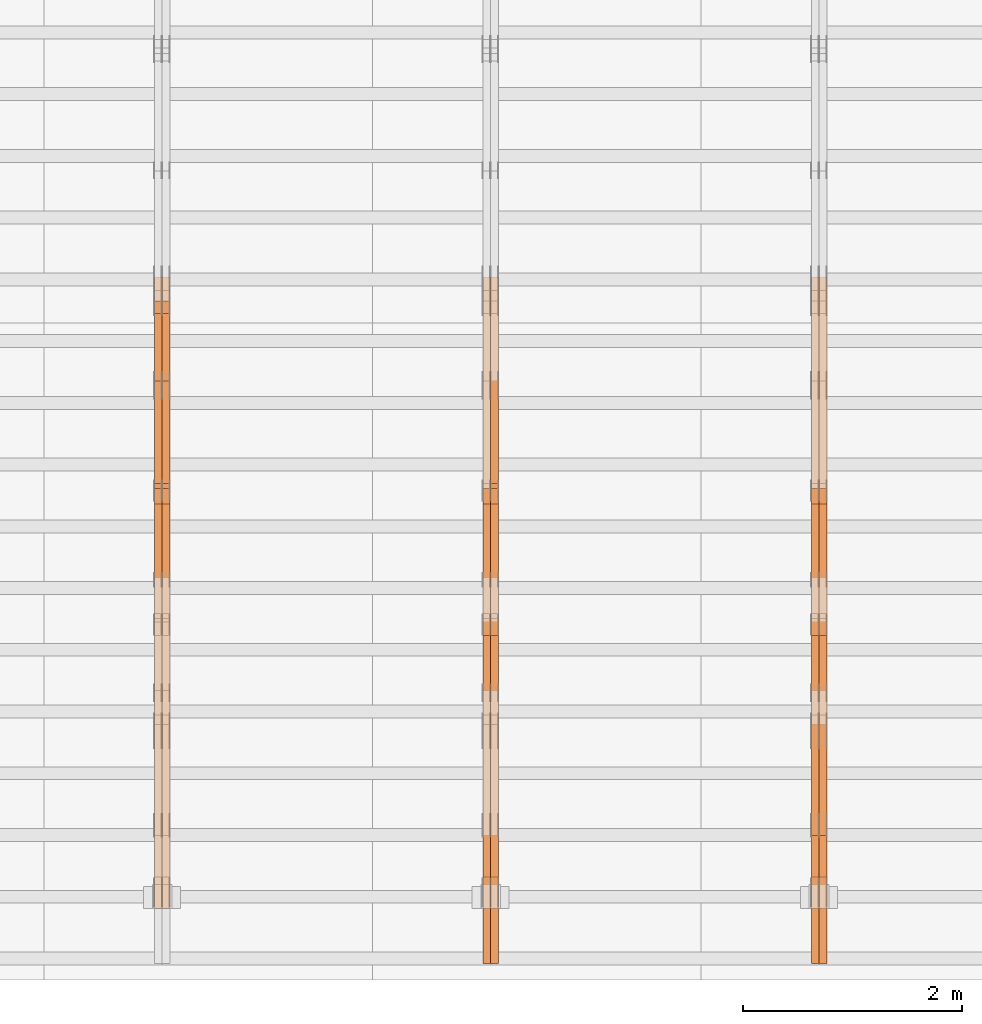
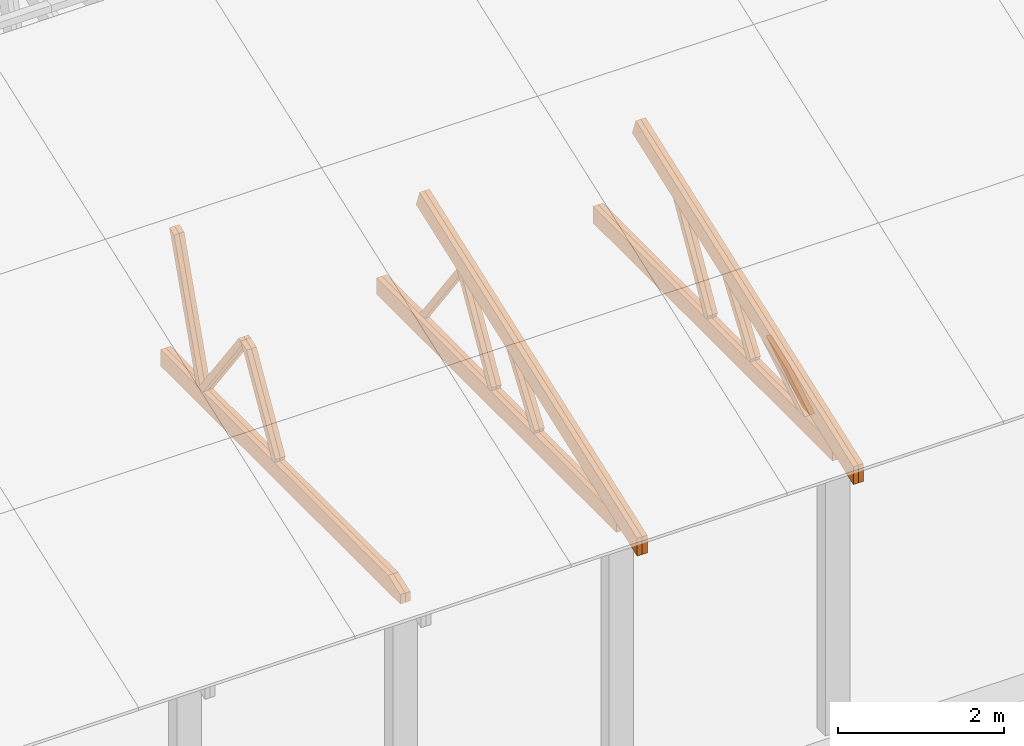
# One storey, part 21 of 189: 27 proxies.
"""IFC2X3 building model written with IfcOpenShell, lengths in millimetres."""

from ifc_helpers import new_model, entity, si_unit, converted_unit, derived_unit, direction, frame, origin, place, context, subcontext, project, spatial, polyline, outline, extrude, source, transform, mapped, material, type_object, type_shapes, element, save


model = new_model("IFC2X3")

# Units and contexts
model_context = context("Model", 3, precision=0.01, world=origin(), true_north=direction((6.12303176911189e-17, 1.0)))
body_context = subcontext(model_context, "Body", "Model", "MODEL_VIEW")
ifc_project = project(units=[si_unit("LENGTHUNIT", "METRE", prefix="MILLI"), si_unit("AREAUNIT", "SQUARE_METRE"), si_unit("VOLUMEUNIT", "CUBIC_METRE"), converted_unit("PLANEANGLEUNIT", "DEGREE", entity("IfcRatioMeasure", 0.0174532925199433), si_unit("PLANEANGLEUNIT", "RADIAN"), dimensions=[0, 0, 0, 0, 0, 0, 0]), si_unit("MASSUNIT", "GRAM", prefix="KILO"), derived_unit("MASSDENSITYUNIT", [(si_unit("MASSUNIT", "GRAM", prefix="KILO"), 1), (si_unit("LENGTHUNIT", "METRE"), -3)]), si_unit("TIMEUNIT", "SECOND"), si_unit("FREQUENCYUNIT", "HERTZ"), si_unit("THERMODYNAMICTEMPERATUREUNIT", "DEGREE_CELSIUS"), derived_unit("THERMALTRANSMITTANCEUNIT", [(si_unit("MASSUNIT", "GRAM", prefix="KILO"), 1), (si_unit("THERMODYNAMICTEMPERATUREUNIT", "KELVIN"), -1), (si_unit("TIMEUNIT", "SECOND"), -3)]), derived_unit("VOLUMETRICFLOWRATEUNIT", [(si_unit("LENGTHUNIT", "METRE"), 3), (si_unit("TIMEUNIT", "SECOND"), -1)]), si_unit("ELECTRICCURRENTUNIT", "AMPERE"), si_unit("ELECTRICVOLTAGEUNIT", "VOLT"), si_unit("POWERUNIT", "WATT"), si_unit("FORCEUNIT", "NEWTON"), si_unit("ILLUMINANCEUNIT", "LUX"), si_unit("LUMINOUSFLUXUNIT", "LUMEN"), si_unit("LUMINOUSINTENSITYUNIT", "CANDELA"), derived_unit("USERDEFINED", [(si_unit("MASSUNIT", "GRAM", prefix="KILO"), -1), (si_unit("LENGTHUNIT", "METRE"), -2), (si_unit("TIMEUNIT", "SECOND"), 3), (si_unit("LUMINOUSFLUXUNIT", "LUMEN"), 1)]), derived_unit("LINEARVELOCITYUNIT", [(si_unit("LENGTHUNIT", "METRE"), 1), (si_unit("TIMEUNIT", "SECOND"), -1)]), si_unit("PRESSUREUNIT", "PASCAL"), derived_unit("USERDEFINED", [(si_unit("LENGTHUNIT", "METRE"), -2), (si_unit("MASSUNIT", "GRAM", prefix="KILO"), 1), (si_unit("TIMEUNIT", "SECOND"), -2)])], contexts=[model_context])

# Site, building, storey
site_placement = place(None, origin())
site = spatial("IfcSite", under=ifc_project, at=site_placement, CompositionType="ELEMENT")
building_placement = place(site_placement, origin())
building = spatial("IfcBuilding", under=site, at=building_placement, CompositionType="ELEMENT")
storey_placement = place(building_placement, origin())
storey = spatial("IfcBuildingStorey", under=building, at=storey_placement, Name="Default", CompositionType="ELEMENT", Elevation=0.0)

# Proxies
ifc_material_1 = material(Name="IfcSurfaceStyle #113364")
building_element_proxy_type_1 = type_object("IfcBuildingElementProxyType", Name="T1-W11 113362", PredefinedType="NOTDEFINED", material=ifc_material_1)
shared_shape_1 = source(origin(), body_context, "Body", "SweptSolid", [
    extrude(outline(polyline([(593.358012843793, -552.565239103314), (742.388662259985, -552.565239103314), (-410.498749190676, 401.275038694583), (-462.246133468927, 382.44069706518), (-463.001792444175, 321.414742446865), (593.358012843793, -552.565239103314)])), frame((599.94412413079, 47.5003788877286, 0.0), z_axis=(0.0, 0.0, 1.0), x_axis=(0.770483455324544, 0.637459994879013, 0.0)), (0.0, 0.0, 1.0), 69.9999999999999),
])
type_shapes(building_element_proxy_type_1, [shared_shape_1])
proxy_1_placement = place(building_placement, frame((21300.0, 2983.26655629375, 269.034992751429), z_axis=(-1.0, 0.0, 0.0), x_axis=(0.0, 0.505995901100606, 0.862535882192379)))
element("IfcBuildingElementProxy", 1, at=proxy_1_placement, inside=storey, type_object=building_element_proxy_type_1, material=ifc_material_1, Name="T1-W11", context=body_context, shape_type="MappedRepresentation", body=[
    mapped(shared_shape_1, transform((0.0, 0.0, 0.0), scale=1.0)),
])
ifc_material_2 = material(Name="IfcSurfaceStyle #113298")
building_element_proxy_type_2 = type_object("IfcBuildingElementProxyType", Name="T1-W11 113296", PredefinedType="NOTDEFINED", material=ifc_material_2)
shared_shape_2 = source(origin(), body_context, "Body", "SweptSolid", [
    extrude(outline(polyline([(593.358012843793, -552.565239103314), (742.388662259985, -552.565239103314), (-410.498749190676, 401.275038694583), (-462.246133468927, 382.44069706518), (-463.001792444175, 321.414742446865), (593.358012843793, -552.565239103314)])), frame((599.94412413079, 47.5003788877286, 0.0), z_axis=(0.0, 0.0, 1.0), x_axis=(0.770483455324544, 0.637459994879013, 0.0)), (0.0, 0.0, 1.0), 69.9999999999999),
])
type_shapes(building_element_proxy_type_2, [shared_shape_2])
proxy_2_placement = place(building_placement, frame((21230.0, 2983.26655629375, 269.034992751429), z_axis=(-1.0, 0.0, 0.0), x_axis=(0.0, 0.505995901100606, 0.862535882192379)))
element("IfcBuildingElementProxy", 2, at=proxy_2_placement, inside=storey, type_object=building_element_proxy_type_2, material=ifc_material_2, Name="T1-W11", context=body_context, shape_type="MappedRepresentation", body=[
    mapped(shared_shape_2, transform((0.0, 0.0, 0.0), scale=1.0)),
])
ifc_material_3 = material(Name="IfcSurfaceStyle #112836")
building_element_proxy_type_3 = type_object("IfcBuildingElementProxyType", Name="T1-W13 112834", PredefinedType="NOTDEFINED", material=ifc_material_3)
shared_shape_3 = source(origin(), body_context, "Body", "SweptSolid", [
    extrude(outline(polyline([(404.740440720218, -341.48092914206), (570.336320797765, -341.48092914206), (-287.911826743206, 259.650691447848), (-342.395697357435, 239.820346030744), (-344.769237417342, 183.490820805529), (404.740440720218, -341.48092914206)])), frame((418.029573061951, 47.5005675782689, 0.0), z_axis=(0.0, 0.0, 1.0), x_axis=(0.819070847746389, 0.573692379565924, 0.0)), (0.0, 0.0, 1.0), 69.9999999999999),
])
type_shapes(building_element_proxy_type_3, [shared_shape_3])
proxy_3_placement = place(building_placement, frame((21300.0, 1951.16403402681, 272.239720286334), z_axis=(-1.0, 0.0, 0.0), x_axis=(0.0, 0.573462629043499, 0.819231721242848)))
element("IfcBuildingElementProxy", 3, at=proxy_3_placement, inside=storey, type_object=building_element_proxy_type_3, material=ifc_material_3, Name="T1-W13", context=body_context, shape_type="MappedRepresentation", body=[
    mapped(shared_shape_3, transform((0.0, 0.0, 0.0), scale=1.0)),
])
ifc_material_4 = material(Name="IfcSurfaceStyle #112770")
building_element_proxy_type_4 = type_object("IfcBuildingElementProxyType", Name="T1-W13 112768", PredefinedType="NOTDEFINED", material=ifc_material_4)
shared_shape_4 = source(origin(), body_context, "Body", "SweptSolid", [
    extrude(outline(polyline([(404.740440720218, -341.48092914206), (570.336320797765, -341.48092914206), (-287.911826743206, 259.650691447848), (-342.395697357435, 239.820346030744), (-344.769237417342, 183.490820805529), (404.740440720218, -341.48092914206)])), frame((418.029573061951, 47.5005675782689, 0.0), z_axis=(0.0, 0.0, 1.0), x_axis=(0.819070847746389, 0.573692379565924, 0.0)), (0.0, 0.0, 1.0), 69.9999999999999),
])
type_shapes(building_element_proxy_type_4, [shared_shape_4])
proxy_4_placement = place(building_placement, frame((21230.0, 1951.16403402681, 272.239720286334), z_axis=(-1.0, 0.0, 0.0), x_axis=(0.0, 0.573462629043499, 0.819231721242848)))
element("IfcBuildingElementProxy", 4, at=proxy_4_placement, inside=storey, type_object=building_element_proxy_type_4, material=ifc_material_4, Name="T1-W13", context=body_context, shape_type="MappedRepresentation", body=[
    mapped(shared_shape_4, transform((0.0, 0.0, 0.0), scale=1.0)),
])
ifc_material_5 = material(Name="IfcSurfaceStyle #112308")
building_element_proxy_type_5 = type_object("IfcBuildingElementProxyType", Name="T1-W12 112306", PredefinedType="NOTDEFINED", material=ifc_material_5)
shared_shape_5 = source(origin(), body_context, "Body", "SweptSolid", [
    extrude(outline(polyline([(-671.888430889784, -47.499785620702), (344.892972119224, -47.499785620702), (503.856463083211, 47.4997856207019), (-176.861004312651, 47.499785620702), (-671.888430889784, -47.499785620702)])), frame((503.857114243549, 47.5002636410509, 0.0), z_axis=(0.0, 0.0, 1.0), x_axis=(-1.0, 0.0, 0.0)), (0.0, 0.0, 1.0), 69.9999999999999),
])
type_shapes(building_element_proxy_type_5, [shared_shape_5])
proxy_5_placement = place(building_placement, frame((21300.0, 665.58122707747, 245.000076287477), z_axis=(-1.0, 0.0, 0.0), x_axis=(0.0, 0.858392121304013, 0.51299411895576)))
element("IfcBuildingElementProxy", 5, at=proxy_5_placement, inside=storey, type_object=building_element_proxy_type_5, material=ifc_material_5, Name="T1-W12", context=body_context, shape_type="MappedRepresentation", body=[
    mapped(shared_shape_5, transform((0.0, 0.0, 0.0), scale=1.0)),
])
ifc_material_6 = material(Name="IfcSurfaceStyle #112251")
building_element_proxy_type_6 = type_object("IfcBuildingElementProxyType", Name="T1-W12 112249", PredefinedType="NOTDEFINED", material=ifc_material_6)
shared_shape_6 = source(origin(), body_context, "Body", "SweptSolid", [
    extrude(outline(polyline([(-671.888430889784, -47.499785620702), (344.892972119224, -47.499785620702), (503.856463083211, 47.4997856207019), (-176.861004312651, 47.499785620702), (-671.888430889784, -47.499785620702)])), frame((503.857114243549, 47.5002636410509, 0.0), z_axis=(0.0, 0.0, 1.0), x_axis=(-1.0, 0.0, 0.0)), (0.0, 0.0, 1.0), 69.9999999999999),
])
type_shapes(building_element_proxy_type_6, [shared_shape_6])
proxy_6_placement = place(building_placement, frame((21230.0, 665.58122707747, 245.000076287477), z_axis=(-1.0, 0.0, 0.0), x_axis=(0.0, 0.858392121304013, 0.51299411895576)))
element("IfcBuildingElementProxy", 6, at=proxy_6_placement, inside=storey, type_object=building_element_proxy_type_6, material=ifc_material_6, Name="T1-W12", context=body_context, shape_type="MappedRepresentation", body=[
    mapped(shared_shape_6, transform((0.0, 0.0, 0.0), scale=1.0)),
])
ifc_material_7 = material(Name="IfcSurfaceStyle #111492")
building_element_proxy_type_7 = type_object("IfcBuildingElementProxyType", Name="T1-B2 111490", PredefinedType="NOTDEFINED", material=ifc_material_7)
shared_shape_7 = source(origin(), body_context, "Body", "SweptSolid", [
    extrude(outline(polyline([(-3399.385546875, -125.855288696291), (2363.08125, -125.855288696291), (2363.08125, 13.4211547851572), (2072.60859375, 119.144711303712), (-3399.385546875, 119.144711303712), (-3399.385546875, -125.855288696291)])), frame((2363.08125, 119.144711303712, 0.0), z_axis=(0.0, 0.0, 1.0), x_axis=(-1.0, 0.0, 0.0)), (0.0, 0.0, 1.0), 69.9999999999997),
])
type_shapes(building_element_proxy_type_7, [shared_shape_7])
proxy_7_placement = place(building_placement, frame((21300.0, 0.0, 245.0), z_axis=(-1.0, 0.0, 0.0), x_axis=(0.0, 1.0, 0.0)))
element("IfcBuildingElementProxy", 7, at=proxy_7_placement, inside=storey, type_object=building_element_proxy_type_7, material=ifc_material_7, Name="T1-B2", context=body_context, shape_type="MappedRepresentation", body=[
    mapped(shared_shape_7, transform((0.0, 0.0, 0.0), scale=1.0)),
])
ifc_material_8 = material(Name="IfcSurfaceStyle #111426")
building_element_proxy_type_8 = type_object("IfcBuildingElementProxyType", Name="T1-B2 111424", PredefinedType="NOTDEFINED", material=ifc_material_8)
shared_shape_8 = source(origin(), body_context, "Body", "SweptSolid", [
    extrude(outline(polyline([(-3399.385546875, -125.855288696291), (2363.08125, -125.855288696291), (2363.08125, 13.4211547851572), (2072.60859375, 119.144711303712), (-3399.385546875, 119.144711303712), (-3399.385546875, -125.855288696291)])), frame((2363.08125, 119.144711303712, 0.0), z_axis=(0.0, 0.0, 1.0), x_axis=(-1.0, 0.0, 0.0)), (0.0, 0.0, 1.0), 69.9999999999997),
])
type_shapes(building_element_proxy_type_8, [shared_shape_8])
proxy_8_placement = place(building_placement, frame((21230.0, 0.0, 245.0), z_axis=(-1.0, 0.0, 0.0), x_axis=(0.0, 1.0, 0.0)))
element("IfcBuildingElementProxy", 8, at=proxy_8_placement, inside=storey, type_object=building_element_proxy_type_8, material=ifc_material_8, Name="T1-B2", context=body_context, shape_type="MappedRepresentation", body=[
    mapped(shared_shape_8, transform((0.0, 0.0, 0.0), scale=1.0)),
])
ifc_material_9 = material(Name="IfcSurfaceStyle #111360")
building_element_proxy_type_9 = type_object("IfcBuildingElementProxyType", Name="T1-T2 111358", PredefinedType="NOTDEFINED", material=ifc_material_9)
shared_shape_9 = source(origin(), body_context, "Body", "SweptSolid", [
    extrude(outline(polyline([(-2763.12044548193, -122.499971764318), (2807.70681121203, -122.499971764318), (2807.70678531127, 122.499971764318), (-2852.29315104137, 122.499971764318), (-2763.12044548193, -122.499971764318)])), frame((2807.70684902043, 122.500023191939, 0.0), z_axis=(0.0, 0.0, 1.0), x_axis=(-1.0, 0.0, 0.0)), (0.0, 0.0, 1.0), 69.9999999999997),
])
type_shapes(building_element_proxy_type_9, [shared_shape_9])
proxy_9_placement = place(building_placement, frame((21300.0, 4818.66023370631, 1893.1253396746), z_axis=(-1.0, 0.0, 0.0), x_axis=(0.0, -0.939692620785908, -0.342020143325669)))
element("IfcBuildingElementProxy", 9, at=proxy_9_placement, inside=storey, type_object=building_element_proxy_type_9, material=ifc_material_9, Name="T1-T2", context=body_context, shape_type="MappedRepresentation", body=[
    mapped(shared_shape_9, transform((0.0, 0.0, 0.0), scale=1.0)),
])
ifc_material_10 = material(Name="IfcSurfaceStyle #111303")
building_element_proxy_type_10 = type_object("IfcBuildingElementProxyType", Name="T1-T2 111301", PredefinedType="NOTDEFINED", material=ifc_material_10)
shared_shape_10 = source(origin(), body_context, "Body", "SweptSolid", [
    extrude(outline(polyline([(-2763.12044548193, -122.499971764318), (2807.70681121203, -122.499971764318), (2807.70678531127, 122.499971764318), (-2852.29315104137, 122.499971764318), (-2763.12044548193, -122.499971764318)])), frame((2807.70684902043, 122.500023191939, 0.0), z_axis=(0.0, 0.0, 1.0), x_axis=(-1.0, 0.0, 0.0)), (0.0, 0.0, 1.0), 69.9999999999997),
])
type_shapes(building_element_proxy_type_10, [shared_shape_10])
proxy_10_placement = place(building_placement, frame((21230.0, 4818.66023370631, 1893.1253396746), z_axis=(-1.0, 0.0, 0.0), x_axis=(0.0, -0.939692620785908, -0.342020143325669)))
element("IfcBuildingElementProxy", 10, at=proxy_10_placement, inside=storey, type_object=building_element_proxy_type_10, material=ifc_material_10, Name="T1-T2", context=body_context, shape_type="MappedRepresentation", body=[
    mapped(shared_shape_10, transform((0.0, 0.0, 0.0), scale=1.0)),
])
ifc_material_11 = material(Name="IfcSurfaceStyle #97838")
building_element_proxy_type_11 = type_object("IfcBuildingElementProxyType", Name="T1-W10 97836", PredefinedType="NOTDEFINED", material=ifc_material_11)
shared_shape_11 = source(origin(), body_context, "Body", "SweptSolid", [
    extrude(outline(polyline([(-922.639472665691, -47.5001890573134), (629.920966338637, -47.5001890573134), (650.067737483374, 0.000694680531158376), (635.89112756682, 47.4998417170478), (-993.240358723139, 47.4998417170478), (-922.639472665691, -47.5001890573134)])), frame((650.068202545693, 47.4999816623145, 0.0), z_axis=(0.0, 0.0, 1.0), x_axis=(-1.0, 0.0, 0.0)), (0.0, 0.0, 1.0), 69.9999999999999),
])
type_shapes(building_element_proxy_type_11, [shared_shape_11])
proxy_11_placement = place(building_placement, frame((18300.0, 3874.56126239818, 1563.95828147518), z_axis=(-1.0, 0.0, 0.0), x_axis=(0.0, 0.596486092002, -0.802623412347398)))
element("IfcBuildingElementProxy", 11, at=proxy_11_placement, inside=storey, type_object=building_element_proxy_type_11, material=ifc_material_11, Name="T1-W10", context=body_context, shape_type="MappedRepresentation", body=[
    mapped(shared_shape_11, transform((0.0, 0.0, 0.0), scale=1.0)),
])
ifc_material_12 = material(Name="IfcSurfaceStyle #97574")
building_element_proxy_type_12 = type_object("IfcBuildingElementProxyType", Name="T1-W11 97572", PredefinedType="NOTDEFINED", material=ifc_material_12)
shared_shape_12 = source(origin(), body_context, "Body", "SweptSolid", [
    extrude(outline(polyline([(593.358012843793, -552.565239103314), (742.388662259985, -552.565239103314), (-410.498749190676, 401.275038694583), (-462.246133468927, 382.44069706518), (-463.001792444175, 321.414742446865), (593.358012843793, -552.565239103314)])), frame((599.94412413079, 47.5003788877286, 0.0), z_axis=(0.0, 0.0, 1.0), x_axis=(0.770483455324544, 0.637459994879013, 0.0)), (0.0, 0.0, 1.0), 69.9999999999999),
])
type_shapes(building_element_proxy_type_12, [shared_shape_12])
proxy_12_placement = place(building_placement, frame((18300.0, 2983.26655629375, 269.034992751429), z_axis=(-1.0, 0.0, 0.0), x_axis=(0.0, 0.505995901100606, 0.862535882192379)))
element("IfcBuildingElementProxy", 12, at=proxy_12_placement, inside=storey, type_object=building_element_proxy_type_12, material=ifc_material_12, Name="T1-W11", context=body_context, shape_type="MappedRepresentation", body=[
    mapped(shared_shape_12, transform((0.0, 0.0, 0.0), scale=1.0)),
])
ifc_material_13 = material(Name="IfcSurfaceStyle #97508")
building_element_proxy_type_13 = type_object("IfcBuildingElementProxyType", Name="T1-W11 97506", PredefinedType="NOTDEFINED", material=ifc_material_13)
shared_shape_13 = source(origin(), body_context, "Body", "SweptSolid", [
    extrude(outline(polyline([(593.358012843793, -552.565239103314), (742.388662259985, -552.565239103314), (-410.498749190676, 401.275038694583), (-462.246133468927, 382.44069706518), (-463.001792444175, 321.414742446865), (593.358012843793, -552.565239103314)])), frame((599.94412413079, 47.5003788877286, 0.0), z_axis=(0.0, 0.0, 1.0), x_axis=(0.770483455324544, 0.637459994879013, 0.0)), (0.0, 0.0, 1.0), 69.9999999999999),
])
type_shapes(building_element_proxy_type_13, [shared_shape_13])
proxy_13_placement = place(building_placement, frame((18230.0, 2983.26655629375, 269.034992751429), z_axis=(-1.0, 0.0, 0.0), x_axis=(0.0, 0.505995901100606, 0.862535882192379)))
element("IfcBuildingElementProxy", 13, at=proxy_13_placement, inside=storey, type_object=building_element_proxy_type_13, material=ifc_material_13, Name="T1-W11", context=body_context, shape_type="MappedRepresentation", body=[
    mapped(shared_shape_13, transform((0.0, 0.0, 0.0), scale=1.0)),
])
ifc_material_14 = material(Name="IfcSurfaceStyle #97046")
building_element_proxy_type_14 = type_object("IfcBuildingElementProxyType", Name="T1-W13 97044", PredefinedType="NOTDEFINED", material=ifc_material_14)
shared_shape_14 = source(origin(), body_context, "Body", "SweptSolid", [
    extrude(outline(polyline([(404.740440720218, -341.48092914206), (570.336320797765, -341.48092914206), (-287.911826743206, 259.650691447848), (-342.395697357435, 239.820346030744), (-344.769237417342, 183.490820805529), (404.740440720218, -341.48092914206)])), frame((418.029573061951, 47.5005675782689, 0.0), z_axis=(0.0, 0.0, 1.0), x_axis=(0.819070847746389, 0.573692379565924, 0.0)), (0.0, 0.0, 1.0), 69.9999999999999),
])
type_shapes(building_element_proxy_type_14, [shared_shape_14])
proxy_14_placement = place(building_placement, frame((18300.0, 1951.16403402681, 272.239720286334), z_axis=(-1.0, 0.0, 0.0), x_axis=(0.0, 0.573462629043499, 0.819231721242848)))
element("IfcBuildingElementProxy", 14, at=proxy_14_placement, inside=storey, type_object=building_element_proxy_type_14, material=ifc_material_14, Name="T1-W13", context=body_context, shape_type="MappedRepresentation", body=[
    mapped(shared_shape_14, transform((0.0, 0.0, 0.0), scale=1.0)),
])
ifc_material_15 = material(Name="IfcSurfaceStyle #96980")
building_element_proxy_type_15 = type_object("IfcBuildingElementProxyType", Name="T1-W13 96978", PredefinedType="NOTDEFINED", material=ifc_material_15)
shared_shape_15 = source(origin(), body_context, "Body", "SweptSolid", [
    extrude(outline(polyline([(404.740440720218, -341.48092914206), (570.336320797765, -341.48092914206), (-287.911826743206, 259.650691447848), (-342.395697357435, 239.820346030744), (-344.769237417342, 183.490820805529), (404.740440720218, -341.48092914206)])), frame((418.029573061951, 47.5005675782689, 0.0), z_axis=(0.0, 0.0, 1.0), x_axis=(0.819070847746389, 0.573692379565924, 0.0)), (0.0, 0.0, 1.0), 69.9999999999999),
])
type_shapes(building_element_proxy_type_15, [shared_shape_15])
proxy_15_placement = place(building_placement, frame((18230.0, 1951.16403402681, 272.239720286334), z_axis=(-1.0, 0.0, 0.0), x_axis=(0.0, 0.573462629043499, 0.819231721242848)))
element("IfcBuildingElementProxy", 15, at=proxy_15_placement, inside=storey, type_object=building_element_proxy_type_15, material=ifc_material_15, Name="T1-W13", context=body_context, shape_type="MappedRepresentation", body=[
    mapped(shared_shape_15, transform((0.0, 0.0, 0.0), scale=1.0)),
])
ifc_material_16 = material(Name="IfcSurfaceStyle #95702")
building_element_proxy_type_16 = type_object("IfcBuildingElementProxyType", Name="T1-B2 95700", PredefinedType="NOTDEFINED", material=ifc_material_16)
shared_shape_16 = source(origin(), body_context, "Body", "SweptSolid", [
    extrude(outline(polyline([(-3399.385546875, -125.855288696291), (2363.08125, -125.855288696291), (2363.08125, 13.4211547851572), (2072.60859375, 119.144711303712), (-3399.385546875, 119.144711303712), (-3399.385546875, -125.855288696291)])), frame((2363.08125, 119.144711303712, 0.0), z_axis=(0.0, 0.0, 1.0), x_axis=(-1.0, 0.0, 0.0)), (0.0, 0.0, 1.0), 69.9999999999997),
])
type_shapes(building_element_proxy_type_16, [shared_shape_16])
proxy_16_placement = place(building_placement, frame((18300.0, 0.0, 245.0), z_axis=(-1.0, 0.0, 0.0), x_axis=(0.0, 1.0, 0.0)))
element("IfcBuildingElementProxy", 16, at=proxy_16_placement, inside=storey, type_object=building_element_proxy_type_16, material=ifc_material_16, Name="T1-B2", context=body_context, shape_type="MappedRepresentation", body=[
    mapped(shared_shape_16, transform((0.0, 0.0, 0.0), scale=1.0)),
])
ifc_material_17 = material(Name="IfcSurfaceStyle #95636")
building_element_proxy_type_17 = type_object("IfcBuildingElementProxyType", Name="T1-B2 95634", PredefinedType="NOTDEFINED", material=ifc_material_17)
shared_shape_17 = source(origin(), body_context, "Body", "SweptSolid", [
    extrude(outline(polyline([(-3399.385546875, -125.855288696291), (2363.08125, -125.855288696291), (2363.08125, 13.4211547851572), (2072.60859375, 119.144711303712), (-3399.385546875, 119.144711303712), (-3399.385546875, -125.855288696291)])), frame((2363.08125, 119.144711303712, 0.0), z_axis=(0.0, 0.0, 1.0), x_axis=(-1.0, 0.0, 0.0)), (0.0, 0.0, 1.0), 69.9999999999997),
])
type_shapes(building_element_proxy_type_17, [shared_shape_17])
proxy_17_placement = place(building_placement, frame((18230.0, 0.0, 245.0), z_axis=(-1.0, 0.0, 0.0), x_axis=(0.0, 1.0, 0.0)))
element("IfcBuildingElementProxy", 17, at=proxy_17_placement, inside=storey, type_object=building_element_proxy_type_17, material=ifc_material_17, Name="T1-B2", context=body_context, shape_type="MappedRepresentation", body=[
    mapped(shared_shape_17, transform((0.0, 0.0, 0.0), scale=1.0)),
])
ifc_material_18 = material(Name="IfcSurfaceStyle #95570")
building_element_proxy_type_18 = type_object("IfcBuildingElementProxyType", Name="T1-T2 95568", PredefinedType="NOTDEFINED", material=ifc_material_18)
shared_shape_18 = source(origin(), body_context, "Body", "SweptSolid", [
    extrude(outline(polyline([(-2763.12044548193, -122.499971764318), (2807.70681121203, -122.499971764318), (2807.70678531127, 122.499971764318), (-2852.29315104137, 122.499971764318), (-2763.12044548193, -122.499971764318)])), frame((2807.70684902043, 122.500023191939, 0.0), z_axis=(0.0, 0.0, 1.0), x_axis=(-1.0, 0.0, 0.0)), (0.0, 0.0, 1.0), 69.9999999999997),
])
type_shapes(building_element_proxy_type_18, [shared_shape_18])
proxy_18_placement = place(building_placement, frame((18300.0, 4818.66023370631, 1893.1253396746), z_axis=(-1.0, 0.0, 0.0), x_axis=(0.0, -0.939692620785908, -0.342020143325669)))
element("IfcBuildingElementProxy", 18, at=proxy_18_placement, inside=storey, type_object=building_element_proxy_type_18, material=ifc_material_18, Name="T1-T2", context=body_context, shape_type="MappedRepresentation", body=[
    mapped(shared_shape_18, transform((0.0, 0.0, 0.0), scale=1.0)),
])
ifc_material_19 = material(Name="IfcSurfaceStyle #95513")
building_element_proxy_type_19 = type_object("IfcBuildingElementProxyType", Name="T1-T2 95511", PredefinedType="NOTDEFINED", material=ifc_material_19)
shared_shape_19 = source(origin(), body_context, "Body", "SweptSolid", [
    extrude(outline(polyline([(-2763.12044548193, -122.499971764318), (2807.70681121203, -122.499971764318), (2807.70678531127, 122.499971764318), (-2852.29315104137, 122.499971764318), (-2763.12044548193, -122.499971764318)])), frame((2807.70684902043, 122.500023191939, 0.0), z_axis=(0.0, 0.0, 1.0), x_axis=(-1.0, 0.0, 0.0)), (0.0, 0.0, 1.0), 69.9999999999997),
])
type_shapes(building_element_proxy_type_19, [shared_shape_19])
proxy_19_placement = place(building_placement, frame((18230.0, 4818.66023370631, 1893.1253396746), z_axis=(-1.0, 0.0, 0.0), x_axis=(0.0, -0.939692620785908, -0.342020143325669)))
element("IfcBuildingElementProxy", 19, at=proxy_19_placement, inside=storey, type_object=building_element_proxy_type_19, material=ifc_material_19, Name="T1-T2", context=body_context, shape_type="MappedRepresentation", body=[
    mapped(shared_shape_19, transform((0.0, 0.0, 0.0), scale=1.0)),
])
ifc_material_20 = material(Name="IfcSurfaceStyle #82312")
building_element_proxy_type_20 = type_object("IfcBuildingElementProxyType", Name="T1-W9 82310", PredefinedType="NOTDEFINED", material=ifc_material_20)
shared_shape_20 = source(origin(), body_context, "Body", "SweptSolid", [
    extrude(outline(polyline([(-1227.3969292634, -47.5000382896404), (793.242467803064, -47.5000382896404), (809.267705296822, 1.0956605530188e-05), (776.329919980315, 47.5000328113376), (-1151.4431638168, 47.5000328113376), (-1227.3969292634, -47.5000382896404)])), frame((809.267705296822, 47.5000328113376, 0.0), z_axis=(0.0, 0.0, 1.0), x_axis=(-1.0, 0.0, 0.0)), (0.0, 0.0, 1.0), 69.9999999999999),
])
type_shapes(building_element_proxy_type_20, [shared_shape_20])
proxy_20_placement = place(building_placement, frame((15300.0, 4809.76380889125, 260.184242613649), z_axis=(-1.0, 0.0, 0.0), x_axis=(0.0, 0.31966811847134, 0.947529574226047)))
element("IfcBuildingElementProxy", 20, at=proxy_20_placement, inside=storey, type_object=building_element_proxy_type_20, material=ifc_material_20, Name="T1-W9", context=body_context, shape_type="MappedRepresentation", body=[
    mapped(shared_shape_20, transform((0.0, 0.0, 0.0), scale=1.0)),
])
ifc_material_21 = material(Name="IfcSurfaceStyle #82246")
building_element_proxy_type_21 = type_object("IfcBuildingElementProxyType", Name="T1-W9 82244", PredefinedType="NOTDEFINED", material=ifc_material_21)
shared_shape_21 = source(origin(), body_context, "Body", "SweptSolid", [
    extrude(outline(polyline([(-1227.3969292634, -47.5000382896404), (793.242467803064, -47.5000382896404), (809.267705296822, 1.0956605530188e-05), (776.329919980315, 47.5000328113376), (-1151.4431638168, 47.5000328113376), (-1227.3969292634, -47.5000382896404)])), frame((809.267705296822, 47.5000328113376, 0.0), z_axis=(0.0, 0.0, 1.0), x_axis=(-1.0, 0.0, 0.0)), (0.0, 0.0, 1.0), 69.9999999999999),
])
type_shapes(building_element_proxy_type_21, [shared_shape_21])
proxy_21_placement = place(building_placement, frame((15230.0, 4809.76380889125, 260.184242613649), z_axis=(-1.0, 0.0, 0.0), x_axis=(0.0, 0.31966811847134, 0.947529574226047)))
element("IfcBuildingElementProxy", 21, at=proxy_21_placement, inside=storey, type_object=building_element_proxy_type_21, material=ifc_material_21, Name="T1-W9", context=body_context, shape_type="MappedRepresentation", body=[
    mapped(shared_shape_21, transform((0.0, 0.0, 0.0), scale=1.0)),
])
ifc_material_22 = material(Name="IfcSurfaceStyle #82048")
building_element_proxy_type_22 = type_object("IfcBuildingElementProxyType", Name="T1-W10 82046", PredefinedType="NOTDEFINED", material=ifc_material_22)
shared_shape_22 = source(origin(), body_context, "Body", "SweptSolid", [
    extrude(outline(polyline([(-922.639472665691, -47.5001890573134), (629.920966338637, -47.5001890573134), (650.067737483374, 0.000694680531158376), (635.89112756682, 47.4998417170478), (-993.240358723139, 47.4998417170478), (-922.639472665691, -47.5001890573134)])), frame((650.068202545693, 47.4999816623145, 0.0), z_axis=(0.0, 0.0, 1.0), x_axis=(-1.0, 0.0, 0.0)), (0.0, 0.0, 1.0), 69.9999999999999),
])
type_shapes(building_element_proxy_type_22, [shared_shape_22])
proxy_22_placement = place(building_placement, frame((15300.0, 3874.56126239818, 1563.95828147518), z_axis=(-1.0, 0.0, 0.0), x_axis=(0.0, 0.596486092002, -0.802623412347398)))
element("IfcBuildingElementProxy", 22, at=proxy_22_placement, inside=storey, type_object=building_element_proxy_type_22, material=ifc_material_22, Name="T1-W10", context=body_context, shape_type="MappedRepresentation", body=[
    mapped(shared_shape_22, transform((0.0, 0.0, 0.0), scale=1.0)),
])
ifc_material_23 = material(Name="IfcSurfaceStyle #81982")
building_element_proxy_type_23 = type_object("IfcBuildingElementProxyType", Name="T1-W10 81980", PredefinedType="NOTDEFINED", material=ifc_material_23)
shared_shape_23 = source(origin(), body_context, "Body", "SweptSolid", [
    extrude(outline(polyline([(-922.639472665691, -47.5001890573134), (629.920966338637, -47.5001890573134), (650.067737483374, 0.000694680531158376), (635.89112756682, 47.4998417170478), (-993.240358723139, 47.4998417170478), (-922.639472665691, -47.5001890573134)])), frame((650.068202545693, 47.4999816623145, 0.0), z_axis=(0.0, 0.0, 1.0), x_axis=(-1.0, 0.0, 0.0)), (0.0, 0.0, 1.0), 69.9999999999999),
])
type_shapes(building_element_proxy_type_23, [shared_shape_23])
proxy_23_placement = place(building_placement, frame((15230.0, 3874.56126239818, 1563.95828147518), z_axis=(-1.0, 0.0, 0.0), x_axis=(0.0, 0.596486092002, -0.802623412347398)))
element("IfcBuildingElementProxy", 23, at=proxy_23_placement, inside=storey, type_object=building_element_proxy_type_23, material=ifc_material_23, Name="T1-W10", context=body_context, shape_type="MappedRepresentation", body=[
    mapped(shared_shape_23, transform((0.0, 0.0, 0.0), scale=1.0)),
])
ifc_material_24 = material(Name="IfcSurfaceStyle #81784")
building_element_proxy_type_24 = type_object("IfcBuildingElementProxyType", Name="T1-W11 81782", PredefinedType="NOTDEFINED", material=ifc_material_24)
shared_shape_24 = source(origin(), body_context, "Body", "SweptSolid", [
    extrude(outline(polyline([(593.358012843793, -552.565239103314), (742.388662259985, -552.565239103314), (-410.498749190676, 401.275038694583), (-462.246133468927, 382.44069706518), (-463.001792444175, 321.414742446865), (593.358012843793, -552.565239103314)])), frame((599.94412413079, 47.5003788877286, 0.0), z_axis=(0.0, 0.0, 1.0), x_axis=(0.770483455324544, 0.637459994879013, 0.0)), (0.0, 0.0, 1.0), 69.9999999999999),
])
type_shapes(building_element_proxy_type_24, [shared_shape_24])
proxy_24_placement = place(building_placement, frame((15300.0, 2983.26655629375, 269.034992751429), z_axis=(-1.0, 0.0, 0.0), x_axis=(0.0, 0.505995901100606, 0.862535882192379)))
element("IfcBuildingElementProxy", 24, at=proxy_24_placement, inside=storey, type_object=building_element_proxy_type_24, material=ifc_material_24, Name="T1-W11", context=body_context, shape_type="MappedRepresentation", body=[
    mapped(shared_shape_24, transform((0.0, 0.0, 0.0), scale=1.0)),
])
ifc_material_25 = material(Name="IfcSurfaceStyle #81718")
building_element_proxy_type_25 = type_object("IfcBuildingElementProxyType", Name="T1-W11 81716", PredefinedType="NOTDEFINED", material=ifc_material_25)
shared_shape_25 = source(origin(), body_context, "Body", "SweptSolid", [
    extrude(outline(polyline([(593.358012843793, -552.565239103314), (742.388662259985, -552.565239103314), (-410.498749190676, 401.275038694583), (-462.246133468927, 382.44069706518), (-463.001792444175, 321.414742446865), (593.358012843793, -552.565239103314)])), frame((599.94412413079, 47.5003788877286, 0.0), z_axis=(0.0, 0.0, 1.0), x_axis=(0.770483455324544, 0.637459994879013, 0.0)), (0.0, 0.0, 1.0), 69.9999999999999),
])
type_shapes(building_element_proxy_type_25, [shared_shape_25])
proxy_25_placement = place(building_placement, frame((15230.0, 2983.26655629375, 269.034992751429), z_axis=(-1.0, 0.0, 0.0), x_axis=(0.0, 0.505995901100606, 0.862535882192379)))
element("IfcBuildingElementProxy", 25, at=proxy_25_placement, inside=storey, type_object=building_element_proxy_type_25, material=ifc_material_25, Name="T1-W11", context=body_context, shape_type="MappedRepresentation", body=[
    mapped(shared_shape_25, transform((0.0, 0.0, 0.0), scale=1.0)),
])
ifc_material_26 = material(Name="IfcSurfaceStyle #79912")
building_element_proxy_type_26 = type_object("IfcBuildingElementProxyType", Name="T1-B2 79910", PredefinedType="NOTDEFINED", material=ifc_material_26)
shared_shape_26 = source(origin(), body_context, "Body", "SweptSolid", [
    extrude(outline(polyline([(-3399.385546875, -125.855288696291), (2363.08125, -125.855288696291), (2363.08125, 13.4211547851572), (2072.60859375, 119.144711303712), (-3399.385546875, 119.144711303712), (-3399.385546875, -125.855288696291)])), frame((2363.08125, 119.144711303712, 0.0), z_axis=(0.0, 0.0, 1.0), x_axis=(-1.0, 0.0, 0.0)), (0.0, 0.0, 1.0), 69.9999999999997),
])
type_shapes(building_element_proxy_type_26, [shared_shape_26])
proxy_26_placement = place(building_placement, frame((15300.0, 0.0, 245.0), z_axis=(-1.0, 0.0, 0.0), x_axis=(0.0, 1.0, 0.0)))
element("IfcBuildingElementProxy", 26, at=proxy_26_placement, inside=storey, type_object=building_element_proxy_type_26, material=ifc_material_26, Name="T1-B2", context=body_context, shape_type="MappedRepresentation", body=[
    mapped(shared_shape_26, transform((0.0, 0.0, 0.0), scale=1.0)),
])
ifc_material_27 = material(Name="IfcSurfaceStyle #79846")
building_element_proxy_type_27 = type_object("IfcBuildingElementProxyType", Name="T1-B2 79844", PredefinedType="NOTDEFINED", material=ifc_material_27)
shared_shape_27 = source(origin(), body_context, "Body", "SweptSolid", [
    extrude(outline(polyline([(-3399.385546875, -125.855288696291), (2363.08125, -125.855288696291), (2363.08125, 13.4211547851572), (2072.60859375, 119.144711303712), (-3399.385546875, 119.144711303712), (-3399.385546875, -125.855288696291)])), frame((2363.08125, 119.144711303712, 0.0), z_axis=(0.0, 0.0, 1.0), x_axis=(-1.0, 0.0, 0.0)), (0.0, 0.0, 1.0), 69.9999999999997),
])
type_shapes(building_element_proxy_type_27, [shared_shape_27])
proxy_27_placement = place(building_placement, frame((15230.0, 0.0, 245.0), z_axis=(-1.0, 0.0, 0.0), x_axis=(0.0, 1.0, 0.0)))
element("IfcBuildingElementProxy", 27, at=proxy_27_placement, inside=storey, type_object=building_element_proxy_type_27, material=ifc_material_27, Name="T1-B2", context=body_context, shape_type="MappedRepresentation", body=[
    mapped(shared_shape_27, transform((0.0, 0.0, 0.0), scale=1.0)),
])

save(model, "model.ifc")
